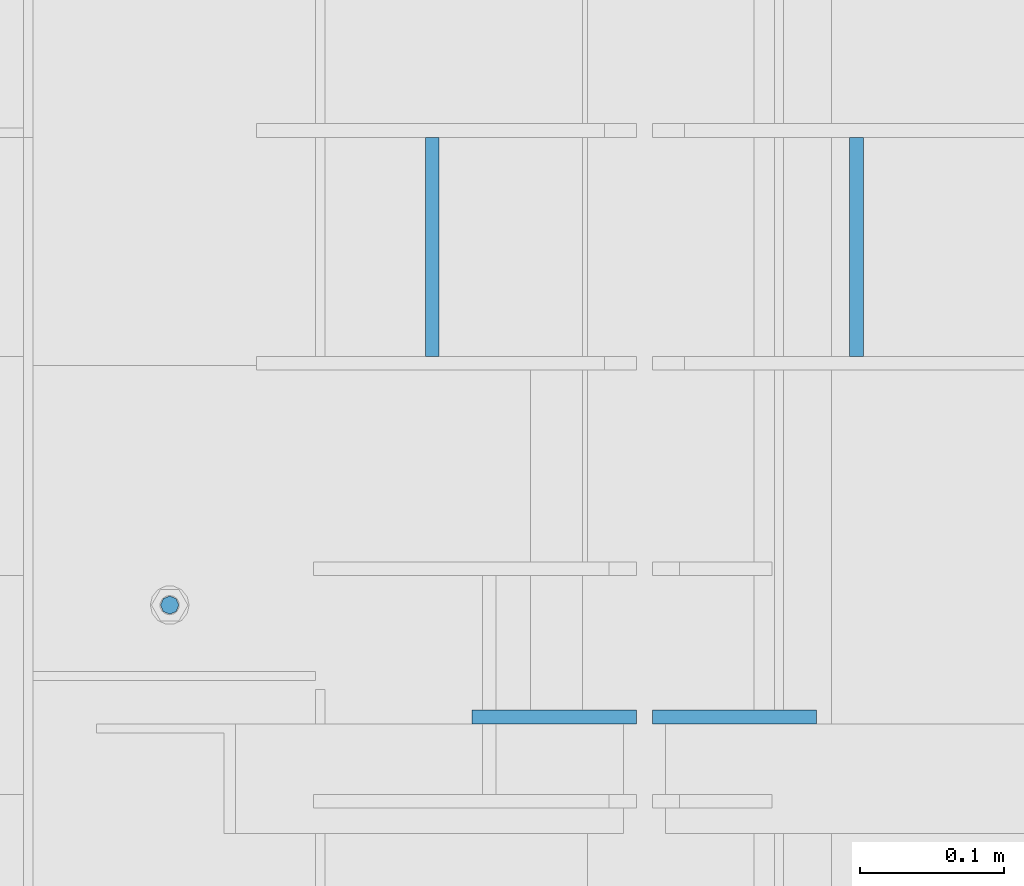
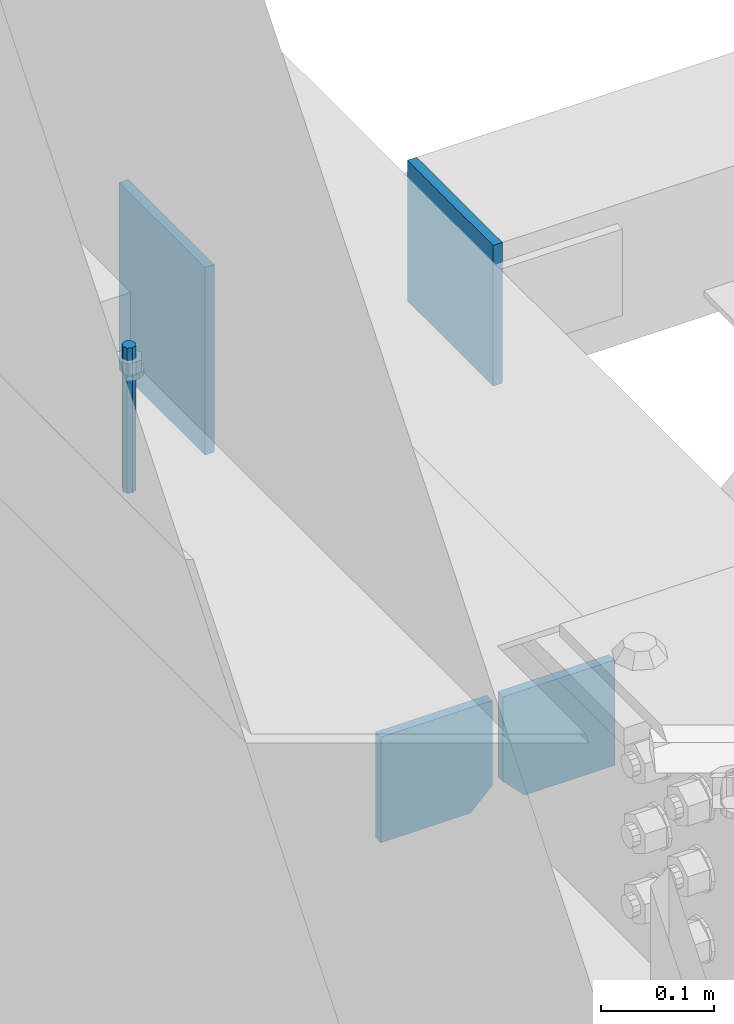
# One storey, part 493 of 1179: 5 columns, 3 elements without a shape of their own.
"""IFC2X3 building model written with IfcOpenShell, lengths in millimetres."""

from ifc_helpers import new_model, si_unit, frame, origin_with_axes, place, context, subcontext, project, spatial, faceted_brep, material, type_object, element, aggregate, save


model = new_model("IFC2X3")

# Units and contexts
model_context = context("Model", 3, precision=1e-05, world=origin_with_axes())
body_context = subcontext(model_context, "Body", "Model", "MODEL_VIEW")
ifc_project = project(units=[si_unit("LENGTHUNIT", "METRE", prefix="MILLI"), si_unit("AREAUNIT", "SQUARE_METRE"), si_unit("VOLUMEUNIT", "CUBIC_METRE"), si_unit("MASSUNIT", "GRAM", prefix="KILO"), si_unit("TIMEUNIT", "SECOND"), si_unit("PLANEANGLEUNIT", "RADIAN"), si_unit("SOLIDANGLEUNIT", "STERADIAN"), si_unit("THERMODYNAMICTEMPERATUREUNIT", "DEGREE_CELSIUS"), si_unit("LUMINOUSINTENSITYUNIT", "LUMEN")], contexts=[model_context])

# Site, building, storey
site_placement = place(None, origin_with_axes())
site = spatial("IfcSite", under=ifc_project, at=site_placement, CompositionType="ELEMENT")
building_placement = place(site_placement, origin_with_axes())
building = spatial("IfcBuilding", under=site, at=building_placement, Name="Undefined", CompositionType="ELEMENT")
storey_placement = place(building_placement, origin_with_axes())
storey = spatial("IfcBuildingStorey", under=building, at=storey_placement, Name="Undefined", CompositionType="ELEMENT", Elevation=0.0)

# Assembly, columns
assembly_1_placement = place(storey_placement, origin_with_axes())
assembly_1 = element("IfcElementAssembly", 1, at=assembly_1_placement, inside=storey, Name="BEAM", AssemblyPlace="NOTDEFINED", PredefinedType="RIGID_FRAME")
ifc_material_1 = material(Name="STEEL/A36")
column_type_1 = type_object("IfcColumnType", PredefinedType="NOTDEFINED")
column_1_placement = place(assembly_1_placement, frame((494.506249999995, 35093.275, 3702.05), z_axis=(-1.0, 0.0, 0.0), x_axis=(0.0, 0.0, 1.0)))
column_1 = element("IfcColumn", 2, at=column_1_placement, type_object=column_type_1, material=ifc_material_1, Name="PLATE", context=body_context, shape_type="Brep", body=[
    faceted_brep([(22.2250000000004, 4.76250000000073, 57.1500000000015), (0.0, 4.76250000000073, 34.9249999999993), (0.0, -4.76250000000073, 34.9249999999993), (22.2250000000004, -4.76250000000073, 57.1500000000015), (114.300000000001, 4.76250000000073, 57.1500000000015), (114.300000000001, 4.76250000000073, -57.1500000000015), (0.0, 4.76250000000073, -57.1500000000015), (114.300000000001, -4.76250000000073, 57.1500000000015), (0.0, -4.76250000000073, -57.1500000000015), (114.300000000001, -4.76250000000073, -57.1500000000015)], [[[0, 1, 2, 3]], [[4, 5, 6, 1, 0]], [[7, 4, 0, 3]], [[8, 9, 7, 3, 2]], [[8, 6, 5, 9]], [[7, 9, 5, 4]], [[6, 8, 2, 1]]]),
])
column_2_placement = place(assembly_1_placement, frame((369.09375, 35093.275, 3702.05), z_axis=(1.0, 0.0, 0.0), x_axis=(0.0, 0.0, 1.0)))
column_2 = element("IfcColumn", 3, at=column_2_placement, type_object=column_type_1, material=ifc_material_1, Name="PLATE", context=body_context, shape_type="Brep", body=[
    faceted_brep([(22.2250000000004, 4.76250000000073, 57.1500000000015), (0.0, 4.76250000000073, 34.9249999999993), (0.0, -4.76250000000073, 34.9249999999993), (22.2250000000004, -4.76250000000073, 57.1500000000015), (114.300000000001, 4.76250000000073, 57.1500000000015), (114.300000000001, 4.76250000000073, -57.1500000000015), (0.0, 4.76250000000073, -57.1500000000015), (114.300000000001, -4.76250000000073, 57.1500000000015), (0.0, -4.76250000000073, -57.1500000000015), (114.300000000001, -4.76250000000073, -57.1500000000015)], [[[0, 1, 2, 3]], [[4, 5, 6, 1, 0]], [[7, 4, 0, 3]], [[8, 9, 7, 3, 2]], [[8, 6, 5, 9]], [[7, 9, 5, 4]], [[6, 8, 2, 1]]]),
])
ifc_material_2 = material(Name="STEEL/A307")
column_type_2 = type_object("IfcColumnType", PredefinedType="NOTDEFINED")
column_3_placement = place(assembly_1_placement, frame((101.600000333522, 35171.0624998706, 4108.45), z_axis=(0.0, 1.0, 0.0), x_axis=(0.0, 0.0, 1.0)))
column_3 = element("IfcColumn", 4, at=column_3_placement, type_object=column_type_2, material=ifc_material_2, Name="THREADED ROD", context=body_context, shape_type="Brep", body=[
    faceted_brep([(0.0, -6.34999999999854, 0.0), (0.0, -4.49012806053361, -4.49012806053452), (157.162499999999, -4.49012806053361, -4.49012806053361), (157.162499999999, -6.34999999999854, 0.0), (0.0, 0.0, -6.34999999999991), (157.162499999999, 0.0, -6.34999999999854), (0.0, 4.49012806053361, -4.49012806053452), (157.162499999999, 4.49012806053361, -4.49012806053361), (0.0, 6.34999999999854, 0.0), (157.162499999999, 6.34999999999854, 0.0), (0.0, 4.49012806053361, 4.49012806053452), (157.162499999999, 4.49012806053361, 4.49012806053361), (0.0, 0.0, 6.34999999999991), (157.162499999999, 0.0, 6.34999999999854), (0.0, -4.49012806053361, 4.49012806053452), (157.162499999999, -4.49012806053361, 4.49012806053361)], [[[0, 1, 2, 3]], [[1, 4, 5, 2]], [[4, 6, 7, 5]], [[6, 8, 9, 7]], [[8, 10, 11, 9]], [[10, 12, 13, 11]], [[12, 14, 15, 13]], [[14, 0, 3, 15]], [[5, 7, 9, 11, 13, 15, 3, 2]], [[14, 12, 10, 8, 6, 4, 1, 0]]]),
])
aggregate(assembly_1, [column_3, column_1, column_2])

# Assembly, column
assembly_2_placement = place(storey_placement, origin_with_axes())
assembly_2 = element("IfcElementAssembly", 5, at=assembly_2_placement, inside=storey, Name="BEAM", AssemblyPlace="NOTDEFINED", PredefinedType="RIGID_FRAME")
column_type_3 = type_object("IfcColumnType", PredefinedType="NOTDEFINED")
column_4_placement = place(assembly_2_placement, frame((284.162499999999, 35420.3000000027, 3978.27499999882), z_axis=(0.0, 1.0, 0.0), x_axis=(0.0, 0.0, 1.0)))
column_4 = element("IfcColumn", 6, at=column_4_placement, type_object=column_type_3, material=ifc_material_1, Name="PLATE", context=body_context, shape_type="Brep", body=[
    faceted_brep([(0.0, 4.76249999999982, -76.1999999999971), (0.0, 4.76249999999982, 76.1999999999971), (203.2, 4.76249999999982, 76.1999999999971), (203.2, 4.76249999999982, -76.1999999999971), (0.0, -4.76249999999982, 76.1999999999971), (203.2, -4.76249999999982, 76.1999999999971), (0.0, -4.76249999999982, -76.1999999999971), (203.2, -4.76249999999982, -76.1999999999971)], [[[0, 1, 2, 3]], [[1, 4, 5, 2]], [[4, 6, 7, 5]], [[6, 0, 3, 7]], [[5, 7, 3, 2]], [[6, 4, 1, 0]]]),
])
aggregate(assembly_2, [column_4])

assembly_3_placement = place(storey_placement, origin_with_axes())
assembly_3 = element("IfcElementAssembly", 7, at=assembly_3_placement, inside=storey, Name="BEAM", AssemblyPlace="NOTDEFINED", PredefinedType="RIGID_FRAME")
column_5_placement = place(assembly_3_placement, frame((579.434071065935, 35420.2999998789, 3949.7), z_axis=(0.0, -1.0, 0.0), x_axis=(0.0, 0.0, 1.0)))
column_5 = element("IfcColumn", 8, at=column_5_placement, type_object=column_type_3, material=ifc_material_1, Name="PLATE", context=body_context, shape_type="Brep", body=[
    faceted_brep([(0.0, 4.76249999999982, -76.1999999999971), (0.0, 4.76249999999982, 76.1999999999971), (152.4, 4.76249999999709, 76.2), (152.4, 4.76249999999709, -76.2), (0.0, -4.76249999999982, 76.1999999999971), (152.4, -4.76249999999709, 76.2), (0.0, -4.76249999999982, -76.1999999999971), (152.4, -4.76249999999709, -76.2)], [[[0, 1, 2, 3]], [[1, 4, 5, 2]], [[4, 6, 7, 5]], [[6, 0, 3, 7]], [[5, 7, 3, 2]], [[6, 4, 1, 0]]]),
])
aggregate(assembly_3, [column_5])

save(model, "model.ifc")
